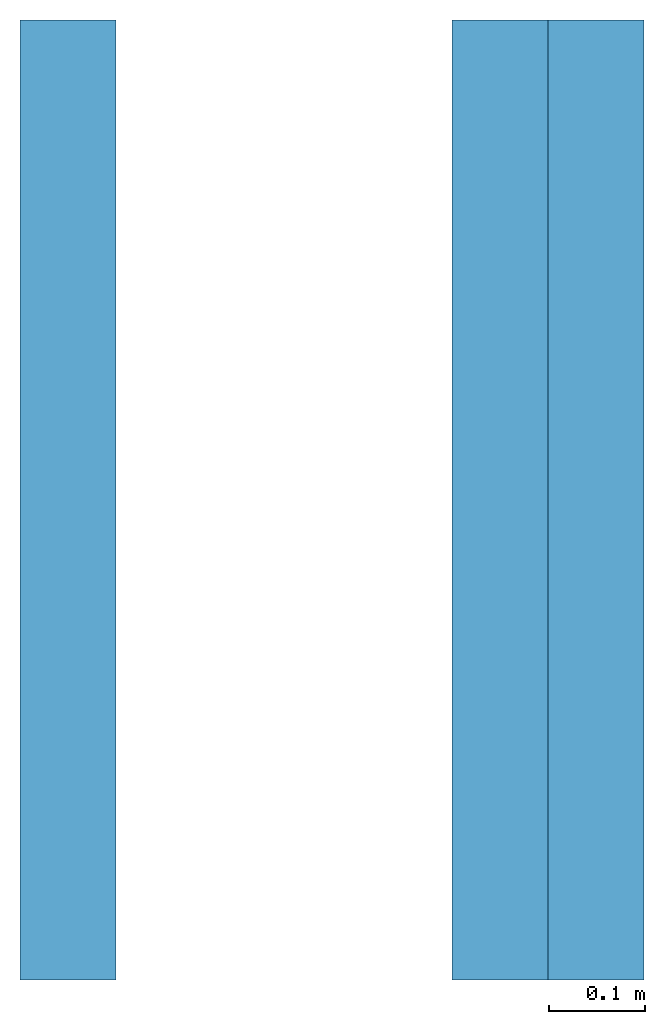
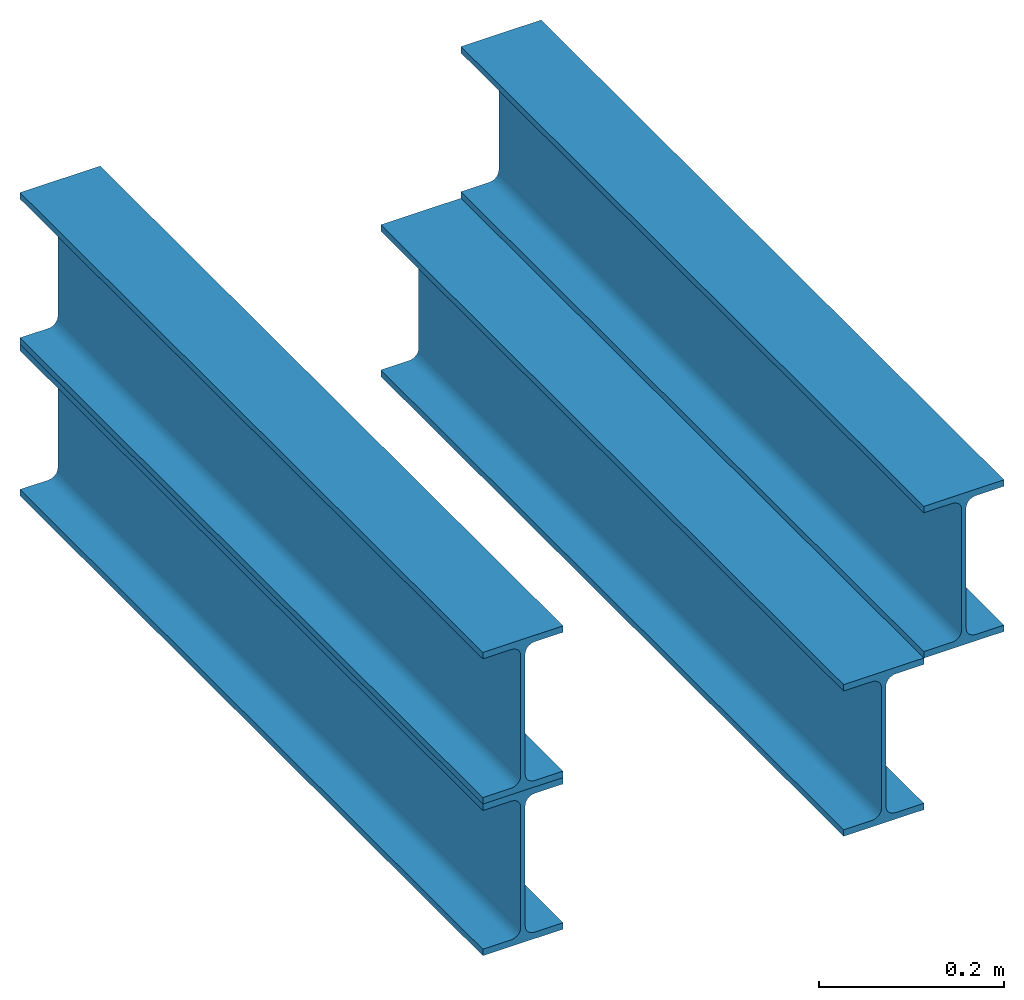
# Not in any storey: 4 beams.
"""IFC4 building model written with IfcOpenShell, lengths in millimetres."""

import ifcopenshell
import ifcopenshell.guid

model = None  # the IFC model being written
_history = None  # IfcOwnerHistory: only IFC2X3 demands one
_inside = {}  # id of a spatial element -> (the spatial element, [elements in it])
_under = {}  # id of a project, library or spatial element -> (it, [spatial elements below it])
_declared = {}  # id of a project -> (the project, [libraries it declares])
_typed = {}  # id of a type object -> (the type object, [elements of that type])
_made_of = {}  # id of a material, layer set ... -> (it, [elements and type objects made of it])


def new_model(schema):
    """Start an empty IFC model of exactly this schema.

    Asked for "IFC4X3", IfcOpenShell would pick the latest addendum, in which some entities
    have other attributes; the version numbers below select the first issue.
    IFC2X3 requires an IfcOwnerHistory on every rooted entity: one is made here for all.
    """
    global model, _history
    if schema == "IFC4X3":
        model = ifcopenshell.file(schema_version=(4, 3, 0, 0))
    else:
        model = ifcopenshell.file(schema=schema)
    _inside.clear()
    _under.clear()
    _declared.clear()
    _typed.clear()
    _made_of.clear()
    _history = None
    if model.schema == "IFC2X3":
        org = make("IfcOrganization", Name="unknown")
        user = make(
            "IfcPersonAndOrganization",
            ThePerson=make("IfcPerson", FamilyName="unknown"),
            TheOrganization=org,
        )
        app = make(
            "IfcApplication",
            ApplicationDeveloper=org,
            Version="unknown",
            ApplicationFullName="unknown",
            ApplicationIdentifier="unknown",
        )
        _history = make(
            "IfcOwnerHistory",
            OwningUser=user,
            OwningApplication=app,
            ChangeAction="ADDED",
            CreationDate=0,
        )
    return model


def make(cls, **values):
    """One entity of the class cls with the attributes given. An attribute that is None is left unset."""
    return model.create_entity(
        cls, **{name: value for name, value in values.items() if value is not None}
    )


def rooted(cls, **values):
    """An entity with a GlobalId (a new one), such as an element, a storey or a relation."""
    return make(cls, GlobalId=ifcopenshell.guid.new(), OwnerHistory=_history, **values)


def si_unit(unit_type, name, prefix=None):
    """IfcSIUnit, for example si_unit("LENGTHUNIT", "METRE", prefix="MILLI")."""
    return make("IfcSIUnit", UnitType=unit_type, Prefix=prefix, Name=name)


def assignment(units):
    """IfcUnitAssignment: the units of a project."""
    return None if units is None else make("IfcUnitAssignment", Units=units)


def point(xyz):
    """IfcCartesianPoint."""
    return None if xyz is None else make("IfcCartesianPoint", Coordinates=xyz)


def direction(xyz):
    """IfcDirection."""
    return None if xyz is None else make("IfcDirection", DirectionRatios=xyz)


def frame(location, z_axis=None, x_axis=None):
    """IfcAxis2Placement3D, a coordinate frame: its origin and axes. An axis left out is left unset."""
    return make(
        "IfcAxis2Placement3D",
        Location=point(location),
        Axis=direction(z_axis),
        RefDirection=direction(x_axis),
    )


def origin():
    """The frame at (0, 0, 0) with its axes left unset."""
    return frame((0.0, 0.0, 0.0))


def place(relative_to, where):
    """IfcLocalPlacement: puts the frame where relative to a parent placement (None: the world)."""
    return make(
        "IfcLocalPlacement", PlacementRelTo=relative_to, RelativePlacement=where
    )


def context(
    kind, dimensions, precision=None, world=None, true_north=None, identifier=None
):
    """IfcGeometricRepresentationContext, for example the 3D "Model" context."""
    return make(
        "IfcGeometricRepresentationContext",
        ContextIdentifier=identifier,
        ContextType=kind,
        CoordinateSpaceDimension=dimensions,
        Precision=precision,
        WorldCoordinateSystem=world,
        TrueNorth=true_north,
    )


def subcontext(parent, identifier, kind, view, scale=None):
    """IfcGeometricRepresentationSubContext, for example "Body" below "Model"."""
    return make(
        "IfcGeometricRepresentationSubContext",
        ContextIdentifier=identifier,
        ContextType=kind,
        ParentContext=parent,
        TargetScale=scale,
        TargetView=view,
    )


def project(units=None, contexts=None):
    """IfcProject with its units and contexts."""
    return rooted(
        "IfcProject",
        Name="project",
        RepresentationContexts=contexts,
        UnitsInContext=assignment(units),
    )


def spatial(cls, under=None, at=None, **own):
    """A site, building, storey or space (cls), placed at a placement, below another one or the project."""
    s = rooted(cls, ObjectPlacement=at, **own)
    if under is not None:
        _under.setdefault(under.id(), (under, []))[1].append(s)
    return s


def profile(cls, at=None, kind="AREA", **sizes):
    """A parametric profile (cls). Its sizes go by their IFC names, for example OverallWidth=200.0."""
    return make(cls, ProfileType=kind, Position=at, **sizes)


def i_section(**sizes):
    """IfcIShapeProfileDef."""
    return profile("IfcIShapeProfileDef", **sizes)


def extrude(swept, where, along, depth):
    """IfcExtrudedAreaSolid: the profile swept, set in the frame where, extruded along a direction by depth."""
    return make(
        "IfcExtrudedAreaSolid",
        SweptArea=swept,
        Position=where,
        ExtrudedDirection=direction(along),
        Depth=depth,
    )


def shape(context_of_items, identifier, shape_type, items):
    """IfcShapeRepresentation: the items that make up one representation, for example the "Body"."""
    return make(
        "IfcShapeRepresentation",
        ContextOfItems=context_of_items,
        RepresentationIdentifier=identifier,
        RepresentationType=shape_type,
        Items=items,
    )


def made_of(thing, what):
    """Note that an element or type object is made of a material, layer set ...; save() writes the relation."""
    if what is not None:
        _made_of.setdefault(what.id(), (what, []))[1].append(thing)
    return thing


def type_object(cls, material=None, **own):
    """A type object (cls), such as IfcWallType, which elements share."""
    return made_of(rooted(cls, **own), material)


def element(
    cls,
    number,
    at=None,
    inside=None,
    cuts=None,
    type_object=None,
    material=None,
    context=None,
    identifier="Body",
    shape_type=None,
    held_by="IfcProductDefinitionShape",
    body=None,
    shapes=None,
    **own,
):
    """One element of the class cls, such as IfcWall. Its Tag is "e" and its number.

    at: its placement. inside: the storey or other place that contains it. cuts: it is an
    opening in that element (IfcRelVoidsElement). A single representation is given by context,
    identifier, shape_type and body (its items); several are given by shapes. held_by: the class
    of the entity that holds the representations. save() writes the other relations.
    """
    e = rooted(cls, Tag="e%d" % number, ObjectPlacement=at, **own)
    if body is not None:
        shapes = [shape(context, identifier, shape_type, body)]
    if shapes is not None:
        e.Representation = make(held_by, Representations=shapes)
    if inside is not None:
        _inside.setdefault(inside.id(), (inside, []))[1].append(e)
    if cuts is not None:
        rooted(
            "IfcRelVoidsElement", RelatingBuildingElement=cuts, RelatedOpeningElement=e
        )
    if type_object is not None:
        _typed.setdefault(type_object.id(), (type_object, []))[1].append(e)
    return made_of(e, material)


def aggregate(whole, parts):
    """IfcRelAggregates: a whole, such as a stair, and the parts it consists of."""
    return rooted("IfcRelAggregates", RelatingObject=whole, RelatedObjects=parts)


def save(model, path):
    """Write the relations noted so far, then the file.

    IfcRelAggregates (storeys below a building ...), IfcRelContainedInSpatialStructure (elements
    in a storey), IfcRelDefinesByType, IfcRelAssociatesMaterial and IfcRelDeclares: one each for
    every whole, place, type object, material and project.
    """
    for whole, parts in _under.values():
        aggregate(whole, parts)
    for where, things in _inside.values():
        rooted(
            "IfcRelContainedInSpatialStructure",
            RelatedElements=things,
            RelatingStructure=where,
        )
    for kind, things in _typed.values():
        rooted("IfcRelDefinesByType", RelatedObjects=things, RelatingType=kind)
    for what, things in _made_of.values():
        rooted("IfcRelAssociatesMaterial", RelatedObjects=things, RelatingMaterial=what)
    for by, libraries in _declared.values():
        rooted("IfcRelDeclares", RelatingContext=by, RelatedDefinitions=libraries)
    model.write(path)


model = new_model("IFC4")

# Units and contexts
model_context_1 = context("Model", 3, precision=0.0001, world=origin(), true_north=direction((0.0, 1.0)))
model_context_2 = context("Model", 3, precision=0.0001, world=origin(), true_north=direction((0.0, 1.0)))
body_context = subcontext(model_context_1, "Body", "Model", "MODEL_VIEW")
ifc_project = project(units=[si_unit("LENGTHUNIT", "METRE", prefix="MILLI"), si_unit("PLANEANGLEUNIT", "RADIAN"), si_unit("TIMEUNIT", "SECOND")], contexts=[model_context_2])

# Building
building_placement = place(None, origin())
building = spatial("IfcBuilding", under=ifc_project, at=building_placement, Name="IfcBuilding", CompositionType="ELEMENT")

# Beams
beam_type = type_object("IfcBeamType", Name="IPE200", PredefinedType="JOIST")
beam_1_placement = place(None, frame((0.0, 0.0, 0.0), z_axis=(0.0, 1.0, 0.0), x_axis=(-1.0, 0.0, 0.0)))
element("IfcBeamStandardCase", 1, at=beam_1_placement, inside=building, type_object=beam_type, Name="TopMid", context=body_context, shape_type="SweptSolid", body=[
    extrude(i_section(OverallWidth=100.0, OverallDepth=200.0, WebThickness=5.6, FlangeThickness=8.5, FilletRadius=12.0), frame((0.0, -100.0, 0.0), z_axis=(0.0, 0.0, 1.0), x_axis=(1.0, 0.0, 0.0)), (0.0, 0.0, 1.0), 1000.0),
])
beam_2_placement = place(None, frame((0.0, 0.0, 0.0), z_axis=(0.0, 1.0, 0.0), x_axis=(-1.0, 0.0, 0.0)))
element("IfcBeamStandardCase", 2, at=beam_2_placement, inside=building, type_object=beam_type, context=body_context, shape_type="SweptSolid", body=[
    extrude(i_section(OverallWidth=100.0, OverallDepth=200.0, WebThickness=5.6, FlangeThickness=8.5, FilletRadius=12.0), frame((0.0, 100.0, 0.0), z_axis=(0.0, 0.0, 1.0), x_axis=(1.0, 0.0, 0.0)), (0.0, 0.0, 1.0), 1000.0),
])
beam_3_placement = place(None, frame((500.0, 0.0, 0.0), z_axis=(0.0, 1.0, 0.0), x_axis=(-1.0, 0.0, 0.0)))
element("IfcBeamStandardCase", 3, at=beam_3_placement, inside=building, type_object=beam_type, context=body_context, shape_type="SweptSolid", body=[
    extrude(i_section(OverallWidth=100.0, OverallDepth=200.0, WebThickness=5.6, FlangeThickness=8.5, FilletRadius=12.0), frame((-50.0, 100.0, 0.0), z_axis=(0.0, 0.0, 1.0), x_axis=(1.0, 0.0, 0.0)), (0.0, 0.0, 1.0), 1000.0),
])
beam_4_placement = place(None, frame((500.0, 0.0, 0.0), z_axis=(0.0, 1.0, 0.0), x_axis=(-1.0, 0.0, 0.0)))
element("IfcBeamStandardCase", 4, at=beam_4_placement, inside=building, type_object=beam_type, Name="TopRight", context=body_context, shape_type="SweptSolid", body=[
    extrude(i_section(OverallWidth=100.0, OverallDepth=200.0, WebThickness=5.6, FlangeThickness=8.5, FilletRadius=12.0), frame((50.0, -100.0, 0.0), z_axis=(0.0, 0.0, 1.0), x_axis=(1.0, 0.0, 0.0)), (0.0, 0.0, 1.0), 1000.0),
])

save(model, "model.ifc")
